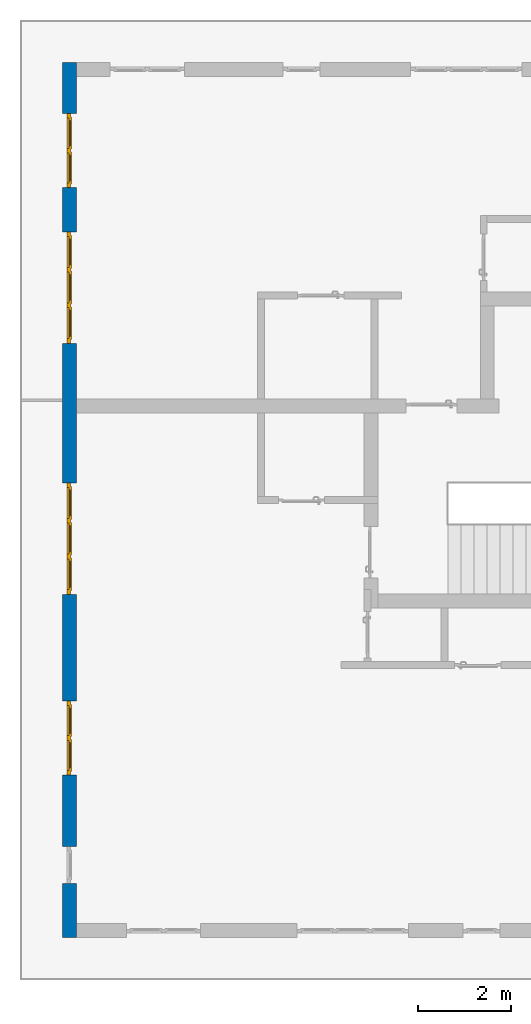
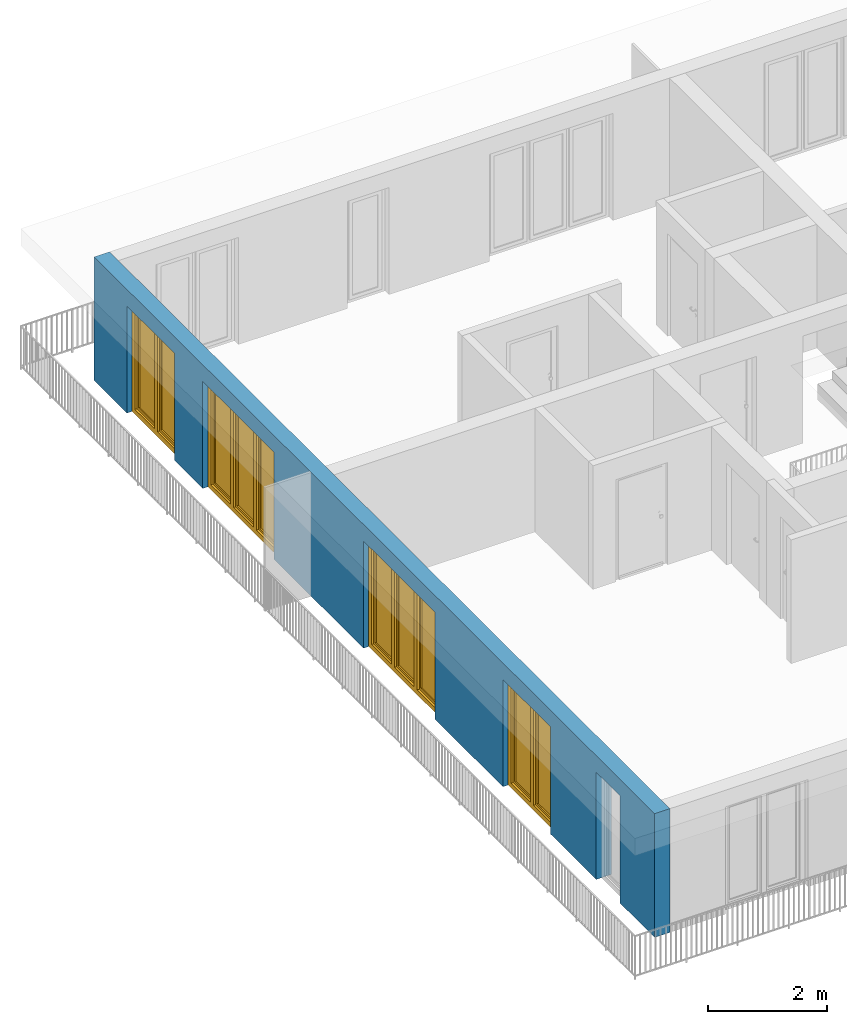
# One storey, part 7 of 48: 4 windows, 1 wall, 5 openings.
"""IFC4 building model written with IfcOpenShell, lengths in metres."""

from ifc_helpers import new_model, entity, si_unit, converted_unit, derived_unit, direction, frame, origin_with_axes, place, context, subcontext, project, spatial, polygons, source, transform, mapped, material, type_object, element, fill, save


model = new_model("IFC4")

# Units and contexts
model_context = context("Model", 3, precision=1e-05, world=origin_with_axes(), true_north=direction((0.0, 1.0)))
body_context = subcontext(model_context, "Body", "Model", "MODEL_VIEW")
ifc_project = project(units=[si_unit("LENGTHUNIT", "METRE"), si_unit("AREAUNIT", "SQUARE_METRE"), si_unit("VOLUMEUNIT", "CUBIC_METRE"), converted_unit("PLANEANGLEUNIT", "DEGREE", entity("IfcPlaneAngleMeasure", 0.0174532925199), si_unit("PLANEANGLEUNIT", "RADIAN"), dimensions=[0, 0, 0, 0, 0, 0, 0]), converted_unit("TIMEUNIT", "Year", entity("IfcTimeMeasure", 31556926.0), si_unit("TIMEUNIT", "SECOND"), dimensions=[0, 0, 1, 0, 0, 0, 0]), si_unit("MASSUNIT", "GRAM", prefix="KILO"), si_unit("THERMODYNAMICTEMPERATUREUNIT", "DEGREE_CELSIUS"), si_unit("LUMINOUSINTENSITYUNIT", "LUMEN"), si_unit("ENERGYUNIT", "JOULE", prefix="MEGA"), derived_unit("THERMALCONDUCTANCEUNIT", [(si_unit("POWERUNIT", "WATT"), 1), (si_unit("LENGTHUNIT", "METRE"), -1), (si_unit("THERMODYNAMICTEMPERATUREUNIT", "KELVIN"), -1)]), derived_unit("SPECIFICHEATCAPACITYUNIT", [(si_unit("ENERGYUNIT", "JOULE"), 1), (si_unit("MASSUNIT", "GRAM", prefix="KILO"), -1), (si_unit("THERMODYNAMICTEMPERATUREUNIT", "KELVIN"), -1)]), derived_unit("MASSDENSITYUNIT", [(si_unit("MASSUNIT", "GRAM", prefix="KILO"), 1), (si_unit("VOLUMEUNIT", "CUBIC_METRE"), -1)])], contexts=[model_context])

# Site, building, storey
site_placement = place(None, origin_with_axes())
site = spatial("IfcSite", under=ifc_project, at=site_placement, CompositionType="ELEMENT")
building_placement = place(site_placement, origin_with_axes())
building = spatial("IfcBuilding", under=site, at=building_placement, CompositionType="ELEMENT")
storey_placement = place(building_placement, frame((0.0, 0.0, 3.4), z_axis=(0.0, 0.0, 1.0), x_axis=(1.0, 0.0, 0.0)))
storey = spatial("IfcBuildingStorey", under=building, at=storey_placement, Name="1. Geschoss", CompositionType="ELEMENT", Elevation=3.4)

# Wall, openings, windows
ifc_material = material()
wall_type = type_object("IfcWallType", Name="300", PredefinedType="NOTDEFINED")
wall_placement = place(storey_placement, frame((-11.7421993804, -9.92881223104, 0.0), z_axis=(0.0, 0.0, 1.0), x_axis=(0.0, 1.0, 0.0)))
wall = element("IfcWall", 1, at=wall_placement, inside=storey, type_object=wall_type, material=ifc_material, Name="Wand-001", PredefinedType="NOTDEFINED", context=body_context, shape_type="Tessellation", body=[
    polygons([(1.16441876325, -0.3, 0.0), (1.16441876325, -0.3, 2.2), (1.96441876325, -0.3, 2.2), (1.96441876325, -0.3, 0.0), (3.5, -0.3, 0.0), (3.5, -0.3, 2.2), (5.1, -0.3, 2.2), (5.1, -0.3, 0.0), (7.3921181063, -0.3, 0.0), (7.3921181063, -0.3, 2.2), (9.7921181063, -0.3, 2.2), (9.7921181063, -0.3, 0.0), (12.8, -0.3, 0.0), (12.8, -0.3, 2.2), (15.2, -0.3, 2.2), (15.2, -0.3, 0.0), (16.15, -0.3, 0.0), (16.15, -0.3, 2.2), (17.75, -0.3, 2.2), (17.75, -0.3, 0.0), (18.85, -0.3, 0.0), (18.85, -0.3, 2.54), (0.0, -0.3, 2.54), (0.0, -0.3, 0.0), (1.16441876325, -0.1, 0.0), (1.16441876325, -0.1, 2.2), (1.96441876325, -0.1, 2.2), (1.96441876325, -0.1, 0.0), (1.96441876325, 0.0, 0.0), (3.5, 0.0, 0.0), (3.5, -0.1, 0.0), (3.5, -0.1, 2.2), (5.1, -0.1, 2.2), (5.1, -0.1, 0.0), (5.1, 0.0, 0.0), (7.3921181063, 0.0, 0.0), (7.3921181063, -0.1, 0.0), (7.3921181063, -0.1, 2.2), (9.7921181063, -0.1, 2.2), (9.7921181063, -0.1, 0.0), (9.7921181063, 0.0, 0.0), (12.8, 0.0, 0.0), (12.8, -0.1, 0.0), (12.8, -0.1, 2.2), (15.2, -0.1, 2.2), (15.2, -0.1, 0.0), (15.2, 0.0, 0.0), (16.15, 0.0, 0.0), (16.15, -0.1, 0.0), (16.15, -0.1, 2.2), (17.75, -0.1, 2.2), (17.75, -0.1, 0.0), (17.75, 0.0, 0.0), (18.85, 0.0, 0.0), (18.85, 0.0, 2.54), (0.0, 0.0, 2.54), (0.0, 0.0, 0.0), (1.16441876325, 0.0, 0.0), (1.16441876325, 0.0, 2.2), (1.96441876325, 0.0, 2.2), (17.75, 0.0, 2.2), (16.15, 0.0, 2.2), (15.2, 0.0, 2.2), (12.8, 0.0, 2.2), (9.7921181063, 0.0, 2.2), (7.3921181063, 0.0, 2.2), (5.1, 0.0, 2.2), (3.5, 0.0, 2.2)], [[[1, 2, 3, 4, 5, 6, 7, 8, 9, 10, 11, 12, 13, 14, 15, 16, 17, 18, 19, 20, 21, 22, 23, 24]], [[2, 1, 25, 26]], [[3, 2, 26, 27]], [[4, 3, 27, 28]], [[4, 28, 29, 30, 31, 5]], [[31, 32, 6, 5]], [[32, 33, 7, 6]], [[33, 34, 8, 7]], [[8, 34, 35, 36, 37, 9]], [[10, 9, 37, 38]], [[11, 10, 38, 39]], [[12, 11, 39, 40]], [[12, 40, 41, 42, 43, 13]], [[43, 44, 14, 13]], [[44, 45, 15, 14]], [[45, 46, 16, 15]], [[16, 46, 47, 48, 49, 17]], [[18, 17, 49, 50]], [[19, 18, 50, 51]], [[20, 19, 51, 52]], [[52, 53, 54, 21, 20]], [[22, 21, 54, 55]], [[22, 55, 56, 23]], [[56, 57, 24, 23]], [[25, 1, 24, 57, 58]], [[26, 25, 58, 59]], [[27, 26, 59, 60]], [[28, 27, 60, 29]], [[30, 29, 60, 59, 58, 57, 56, 55, 54, 53, 61, 62, 48, 47, 63, 64, 42, 41, 65, 66, 36, 35, 67, 68]], [[30, 68, 32, 31]], [[68, 67, 33, 32]], [[67, 35, 34, 33]], [[38, 37, 36, 66]], [[39, 38, 66, 65]], [[40, 39, 65, 41]], [[42, 64, 44, 43]], [[64, 63, 45, 44]], [[63, 47, 46, 45]], [[50, 49, 48, 62]], [[51, 50, 62, 61]], [[52, 51, 61, 53]]], closed=True),
])
opening_1_placement = place(wall_placement, frame((16.95, 0.0, 0.0), z_axis=(0.0, 0.0, 1.0), x_axis=(1.0, 0.0, 0.0)))
opening_1 = element("IfcOpeningElement", 2, at=opening_1_placement, cuts=wall, Name="Fenster-001", context=body_context, identifier="Reference", shape_type="Tessellation", body=[
    polygons([(-0.8, -0.1, 0.0), (-0.8, -0.1, 2.2), (-0.8, 0.000999999999999, 2.2), (-0.8, 0.000999999999999, 0.0), (-0.8, -0.301, 0.0), (-0.8, -0.301, 2.2), (0.8, -0.1, 2.2), (0.8, 0.000999999999999, 2.2), (0.8, -0.301, 2.2), (0.8, 0.000999999999999, 0.0), (0.8, -0.1, 0.0), (0.8, -0.301, 0.0)], [[[1, 2, 3, 4]], [[2, 1, 5, 6]], [[7, 8, 3, 2, 6, 9]], [[8, 10, 4, 3]], [[1, 4, 10, 11, 12, 5]], [[6, 5, 12, 9]], [[7, 11, 10, 8]], [[11, 7, 9, 12]]], closed=True),
])
opening_2_placement = place(wall_placement, frame((14.0, 0.0, 0.0), z_axis=(0.0, 0.0, 1.0), x_axis=(1.0, 0.0, 0.0)))
opening_2 = element("IfcOpeningElement", 3, at=opening_2_placement, cuts=wall, Name="Fenster-002", context=body_context, identifier="Reference", shape_type="Tessellation", body=[
    polygons([(-1.2, -0.1, 0.0), (-1.2, -0.1, 2.2), (-1.2, 0.000999999999999, 2.2), (-1.2, 0.000999999999999, 0.0), (-1.2, -0.301, 0.0), (-1.2, -0.301, 2.2), (1.2, -0.1, 2.2), (1.2, 0.000999999999999, 2.2), (1.2, -0.301, 2.2), (1.2, 0.000999999999999, 0.0), (1.2, -0.1, 0.0), (1.2, -0.301, 0.0)], [[[1, 2, 3, 4]], [[2, 1, 5, 6]], [[7, 8, 3, 2, 6, 9]], [[8, 10, 4, 3]], [[1, 4, 10, 11, 12, 5]], [[6, 5, 12, 9]], [[7, 11, 10, 8]], [[11, 7, 9, 12]]], closed=True),
])
opening_3_placement = place(wall_placement, frame((8.5921181063, 0.0, 0.0), z_axis=(0.0, 0.0, 1.0), x_axis=(1.0, 0.0, 0.0)))
opening_3 = element("IfcOpeningElement", 4, at=opening_3_placement, cuts=wall, Name="Fenster-002", context=body_context, identifier="Reference", shape_type="Tessellation", body=[
    polygons([(-1.2, -0.1, 0.0), (-1.2, -0.1, 2.2), (-1.2, 0.000999999999999, 2.2), (-1.2, 0.000999999999999, 0.0), (-1.2, -0.301, 0.0), (-1.2, -0.301, 2.2), (1.2, -0.1, 2.2), (1.2, 0.000999999999999, 2.2), (1.2, -0.301, 2.2), (1.2, 0.000999999999999, 0.0), (1.2, -0.1, 0.0), (1.2, -0.301, 0.0)], [[[1, 2, 3, 4]], [[2, 1, 5, 6]], [[7, 8, 3, 2, 6, 9]], [[8, 10, 4, 3]], [[1, 4, 10, 11, 12, 5]], [[6, 5, 12, 9]], [[7, 11, 10, 8]], [[11, 7, 9, 12]]], closed=True),
])
opening_4_placement = place(wall_placement, frame((4.3, 0.0, 0.0), z_axis=(0.0, 0.0, 1.0), x_axis=(1.0, 0.0, 0.0)))
opening_4 = element("IfcOpeningElement", 5, at=opening_4_placement, cuts=wall, Name="Fenster-001", context=body_context, identifier="Reference", shape_type="Tessellation", body=[
    polygons([(-0.8, -0.1, 0.0), (-0.8, -0.1, 2.2), (-0.8, 0.000999999999999, 2.2), (-0.8, 0.000999999999999, 0.0), (-0.8, -0.301, 0.0), (-0.8, -0.301, 2.2), (0.8, -0.1, 2.2), (0.8, 0.000999999999999, 2.2), (0.8, -0.301, 2.2), (0.8, 0.000999999999999, 0.0), (0.8, -0.1, 0.0), (0.8, -0.301, 0.0)], [[[1, 2, 3, 4]], [[2, 1, 5, 6]], [[7, 8, 3, 2, 6, 9]], [[8, 10, 4, 3]], [[1, 4, 10, 11, 12, 5]], [[6, 5, 12, 9]], [[7, 11, 10, 8]], [[11, 7, 9, 12]]], closed=True),
])
opening_5_placement = place(wall_placement, frame((1.56441876325, 0.0, 0.0), z_axis=(0.0, 0.0, 1.0), x_axis=(1.0, 0.0, 0.0)))
element("IfcOpeningElement", 6, at=opening_5_placement, cuts=wall, Name="Fenster-003", context=body_context, identifier="Reference", shape_type="Tessellation", body=[
    polygons([(-0.4, -0.1, 0.0), (-0.4, -0.1, 2.2), (-0.4, 0.000999999999999, 2.2), (-0.4, 0.000999999999999, 0.0), (-0.4, -0.301, 0.0), (-0.4, -0.301, 2.2), (0.4, -0.1, 2.2), (0.4, 0.000999999999999, 2.2), (0.4, -0.301, 2.2), (0.4, 0.000999999999999, 0.0), (0.4, -0.1, 0.0), (0.4, -0.301, 0.0)], [[[1, 2, 3, 4]], [[2, 1, 5, 6]], [[7, 8, 3, 2, 6, 9]], [[8, 10, 4, 3]], [[1, 4, 10, 11, 12, 5]], [[6, 5, 12, 9]], [[7, 11, 10, 8]], [[11, 7, 9, 12]]], closed=True),
])
window_type_1 = type_object("IfcWindowType", Name="2-1+1 26", PartitioningType="DOUBLE_PANEL_VERTICAL", PredefinedType="WINDOW")
shared_shape_1 = source(origin_with_axes(), body_context, "Body", "Tessellation", [
    polygons([(0.8, -0.07, 0.0), (0.7, -0.07, 0.1), (0.7, 0.0, 0.1), (0.8, 0.0, 0.0), (0.8, -0.07, 2.2), (0.7, -0.07, 2.1), (0.7, 0.0, 2.1), (0.8, 0.0, 2.2)], [[[1, 2, 3, 4]], [[1, 5, 6, 2]], [[2, 6, 7, 3]], [[4, 3, 7, 8]], [[5, 1, 4, 8]], [[6, 5, 8, 7]]], closed=True),
    polygons([(-0.8, -0.07, 0.0), (-0.8, -0.07, 2.2), (-0.8, 0.0, 2.2), (-0.8, 0.0, 0.0), (-0.7, -0.07, 0.1), (-0.7, -0.07, 2.1), (-0.7, 0.0, 2.1), (-0.7, 0.0, 0.1)], [[[1, 2, 3, 4]], [[1, 5, 6, 2]], [[2, 6, 7, 3]], [[4, 3, 7, 8]], [[5, 1, 4, 8]], [[6, 5, 8, 7]]], closed=True),
    polygons([(0.8, -0.07, 0.0), (-0.8, -0.07, 0.0), (-0.8, 0.0, 0.0), (0.8, 0.0, 0.0), (0.7, -0.07, 0.1), (0.05, -0.07, 0.1), (-0.05, -0.07, 0.1), (-0.7, -0.07, 0.1), (-0.7, 0.0, 0.1), (-0.05, 0.0, 0.1), (0.05, 0.0, 0.1), (0.7, 0.0, 0.1)], [[[1, 2, 3, 4]], [[1, 5, 6, 7, 8, 2]], [[2, 8, 9, 3]], [[4, 3, 9, 10, 11, 12]], [[5, 1, 4, 12]], [[6, 5, 12, 11]], [[7, 6, 11, 10]], [[8, 7, 10, 9]]], closed=True),
    polygons([(0.8, -0.07, 2.2), (0.7, -0.07, 2.1), (0.7, 0.0, 2.1), (0.8, 0.0, 2.2), (-0.8, -0.07, 2.2), (-0.7, -0.07, 2.1), (-0.05, -0.07, 2.1), (0.05, -0.07, 2.1), (0.05, 0.0, 2.1), (-0.05, 0.0, 2.1), (-0.7, 0.0, 2.1), (-0.8, 0.0, 2.2)], [[[1, 2, 3, 4]], [[1, 5, 6, 7, 8, 2]], [[2, 8, 9, 3]], [[4, 3, 9, 10, 11, 12]], [[5, 1, 4, 12]], [[6, 5, 12, 11]], [[7, 6, 11, 10]], [[8, 7, 10, 9]]], closed=True),
    polygons([(0.05, -0.07, 0.1), (-0.05, -0.07, 0.1), (-0.05, 0.0, 0.1), (0.05, 0.0, 0.1), (0.05, -0.07, 2.1), (-0.05, -0.07, 2.1), (-0.05, 0.0, 2.1), (0.05, 0.0, 2.1)], [[[1, 2, 3, 4]], [[1, 5, 6, 2]], [[2, 6, 7, 3]], [[4, 3, 7, 8]], [[5, 1, 4, 8]], [[6, 5, 8, 7]]], closed=True),
    polygons([(0.72, 0.0, 0.08), (0.65, 0.0, 0.15), (0.65, 0.03, 0.15), (0.72, 0.03, 0.08), (0.72, 0.0, 2.12), (0.65, 0.0, 2.05), (0.65, 0.03, 2.05), (0.72, 0.03, 2.12)], [[[1, 2, 3, 4]], [[1, 5, 6, 2]], [[2, 6, 7, 3]], [[4, 3, 7, 8]], [[5, 1, 4, 8]], [[6, 5, 8, 7]]], closed=True),
    polygons([(0.03, 0.0, 0.08), (0.03, 0.03, 0.08), (0.1, 0.03, 0.15), (0.1, 0.0, 0.15), (0.03, 0.0, 2.12), (0.03, 0.03, 2.12), (0.1, 0.03, 2.05), (0.1, 0.0, 2.05)], [[[1, 2, 3, 4]], [[5, 6, 2, 1]], [[2, 6, 7, 3]], [[4, 3, 7, 8]], [[1, 4, 8, 5]], [[8, 7, 6, 5]]], closed=True),
    polygons([(0.72, 0.0, 0.08), (0.03, 0.0, 0.08), (0.03, 0.03, 0.08), (0.72, 0.03, 0.08), (0.65, 0.0, 0.15), (0.1, 0.0, 0.15), (0.1, 0.03, 0.15), (0.65, 0.03, 0.15)], [[[1, 2, 3, 4]], [[1, 5, 6, 2]], [[2, 6, 7, 3]], [[4, 3, 7, 8]], [[5, 1, 4, 8]], [[6, 5, 8, 7]]], closed=True),
    polygons([(0.72, 0.0, 2.12), (0.72, 0.03, 2.12), (0.03, 0.03, 2.12), (0.03, 0.0, 2.12), (0.65, 0.0, 2.05), (0.65, 0.03, 2.05), (0.1, 0.03, 2.05), (0.1, 0.0, 2.05)], [[[1, 2, 3, 4]], [[5, 6, 2, 1]], [[2, 6, 7, 3]], [[4, 3, 7, 8]], [[1, 4, 8, 5]], [[8, 7, 6, 5]]], closed=True),
    polygons([(0.7, -0.03, 0.1), (0.65, -0.03, 0.15), (0.65, 0.0, 0.15), (0.7, 0.0, 0.1), (0.7, -0.03, 2.1), (0.65, -0.03, 2.05), (0.65, 0.0, 2.05), (0.7, 0.0, 2.1)], [[[1, 2, 3, 4]], [[1, 5, 6, 2]], [[2, 6, 7, 3]], [[4, 3, 7, 8]], [[5, 1, 4, 8]], [[6, 5, 8, 7]]], closed=True),
    polygons([(0.05, -0.03, 0.1), (0.05, 0.0, 0.1), (0.1, 0.0, 0.15), (0.1, -0.03, 0.15), (0.05, -0.03, 2.1), (0.05, 0.0, 2.1), (0.1, 0.0, 2.05), (0.1, -0.03, 2.05)], [[[1, 2, 3, 4]], [[5, 6, 2, 1]], [[2, 6, 7, 3]], [[4, 3, 7, 8]], [[1, 4, 8, 5]], [[8, 7, 6, 5]]], closed=True),
    polygons([(0.7, -0.03, 0.1), (0.05, -0.03, 0.1), (0.05, 0.0, 0.1), (0.7, 0.0, 0.1), (0.65, -0.03, 0.15), (0.1, -0.03, 0.15), (0.1, 0.0, 0.15), (0.65, 0.0, 0.15)], [[[1, 2, 3, 4]], [[1, 5, 6, 2]], [[2, 6, 7, 3]], [[4, 3, 7, 8]], [[5, 1, 4, 8]], [[6, 5, 8, 7]]], closed=True),
    polygons([(0.7, -0.03, 2.1), (0.7, 0.0, 2.1), (0.05, 0.0, 2.1), (0.05, -0.03, 2.1), (0.65, -0.03, 2.05), (0.65, 0.0, 2.05), (0.1, 0.0, 2.05), (0.1, -0.03, 2.05)], [[[1, 2, 3, 4]], [[5, 6, 2, 1]], [[2, 6, 7, 3]], [[4, 3, 7, 8]], [[1, 4, 8, 5]], [[8, 7, 6, 5]]], closed=True),
    polygons([(0.65, -0.005, 0.15), (0.1, -0.005, 0.15), (0.1, 0.005, 0.15), (0.65, 0.005, 0.15), (0.65, -0.005, 2.05), (0.1, -0.005, 2.05), (0.1, 0.005, 2.05), (0.65, 0.005, 2.05)], [[[1, 2, 3, 4]], [[1, 5, 6, 2]], [[2, 6, 7, 3]], [[4, 3, 7, 8]], [[5, 1, 4, 8]], [[6, 5, 8, 7]]], closed=True),
    polygons([(-0.03, 0.0, 0.08), (-0.1, 0.0, 0.15), (-0.1, 0.03, 0.15), (-0.03, 0.03, 0.08), (-0.03, 0.0, 2.12), (-0.1, 0.0, 2.05), (-0.1, 0.03, 2.05), (-0.03, 0.03, 2.12)], [[[1, 2, 3, 4]], [[1, 5, 6, 2]], [[2, 6, 7, 3]], [[4, 3, 7, 8]], [[5, 1, 4, 8]], [[6, 5, 8, 7]]], closed=True),
    polygons([(-0.72, 0.0, 0.08), (-0.72, 0.03, 0.08), (-0.65, 0.03, 0.15), (-0.65, 0.0, 0.15), (-0.72, 0.0, 2.12), (-0.72, 0.03, 2.12), (-0.65, 0.03, 2.05), (-0.65, 0.0, 2.05)], [[[1, 2, 3, 4]], [[5, 6, 2, 1]], [[2, 6, 7, 3]], [[4, 3, 7, 8]], [[1, 4, 8, 5]], [[8, 7, 6, 5]]], closed=True),
    polygons([(-0.03, 0.0, 0.08), (-0.72, 0.0, 0.08), (-0.72, 0.03, 0.08), (-0.03, 0.03, 0.08), (-0.1, 0.0, 0.15), (-0.65, 0.0, 0.15), (-0.65, 0.03, 0.15), (-0.1, 0.03, 0.15)], [[[1, 2, 3, 4]], [[1, 5, 6, 2]], [[2, 6, 7, 3]], [[4, 3, 7, 8]], [[5, 1, 4, 8]], [[6, 5, 8, 7]]], closed=True),
    polygons([(-0.03, 0.0, 2.12), (-0.03, 0.03, 2.12), (-0.72, 0.03, 2.12), (-0.72, 0.0, 2.12), (-0.1, 0.0, 2.05), (-0.1, 0.03, 2.05), (-0.65, 0.03, 2.05), (-0.65, 0.0, 2.05)], [[[1, 2, 3, 4]], [[5, 6, 2, 1]], [[2, 6, 7, 3]], [[4, 3, 7, 8]], [[1, 4, 8, 5]], [[8, 7, 6, 5]]], closed=True),
    polygons([(-0.05, -0.03, 0.1), (-0.1, -0.03, 0.15), (-0.1, 0.0, 0.15), (-0.05, 0.0, 0.1), (-0.05, -0.03, 2.1), (-0.1, -0.03, 2.05), (-0.1, 0.0, 2.05), (-0.05, 0.0, 2.1)], [[[1, 2, 3, 4]], [[1, 5, 6, 2]], [[2, 6, 7, 3]], [[4, 3, 7, 8]], [[5, 1, 4, 8]], [[6, 5, 8, 7]]], closed=True),
    polygons([(-0.7, -0.03, 0.1), (-0.7, 0.0, 0.1), (-0.65, 0.0, 0.15), (-0.65, -0.03, 0.15), (-0.7, -0.03, 2.1), (-0.7, 0.0, 2.1), (-0.65, 0.0, 2.05), (-0.65, -0.03, 2.05)], [[[1, 2, 3, 4]], [[5, 6, 2, 1]], [[2, 6, 7, 3]], [[4, 3, 7, 8]], [[1, 4, 8, 5]], [[8, 7, 6, 5]]], closed=True),
    polygons([(-0.05, -0.03, 0.1), (-0.7, -0.03, 0.1), (-0.7, 0.0, 0.1), (-0.05, 0.0, 0.1), (-0.1, -0.03, 0.15), (-0.65, -0.03, 0.15), (-0.65, 0.0, 0.15), (-0.1, 0.0, 0.15)], [[[1, 2, 3, 4]], [[1, 5, 6, 2]], [[2, 6, 7, 3]], [[4, 3, 7, 8]], [[5, 1, 4, 8]], [[6, 5, 8, 7]]], closed=True),
    polygons([(-0.05, -0.03, 2.1), (-0.05, 0.0, 2.1), (-0.7, 0.0, 2.1), (-0.7, -0.03, 2.1), (-0.1, -0.03, 2.05), (-0.1, 0.0, 2.05), (-0.65, 0.0, 2.05), (-0.65, -0.03, 2.05)], [[[1, 2, 3, 4]], [[5, 6, 2, 1]], [[2, 6, 7, 3]], [[4, 3, 7, 8]], [[1, 4, 8, 5]], [[8, 7, 6, 5]]], closed=True),
    polygons([(-0.1, -0.005, 0.15), (-0.65, -0.005, 0.15), (-0.65, 0.005, 0.15), (-0.1, 0.005, 0.15), (-0.1, -0.005, 2.05), (-0.65, -0.005, 2.05), (-0.65, 0.005, 2.05), (-0.1, 0.005, 2.05)], [[[1, 2, 3, 4]], [[1, 5, 6, 2]], [[2, 6, 7, 3]], [[4, 3, 7, 8]], [[5, 1, 4, 8]], [[6, 5, 8, 7]]], closed=True),
])
window_1_placement = place(opening_1_placement, frame((0.8, 0.0, 0.0), z_axis=(0.0, 0.0, 1.0), x_axis=(-1.0, 0.0, 0.0)))
window_1 = element("IfcWindow", 7, at=window_1_placement, inside=storey, type_object=window_type_1, Name="Fenster-001", OverallHeight=2.2, OverallWidth=1.6, PredefinedType="WINDOW", context=body_context, shape_type="MappedRepresentation", body=[
    mapped(shared_shape_1, transform((0.8, 0.17, 0.0))),
])
fill(opening_1, window_1)
window_2_placement = place(opening_4_placement, frame((0.8, 0.0, 0.0), z_axis=(0.0, 0.0, 1.0), x_axis=(-1.0, 0.0, 0.0)))
window_2 = element("IfcWindow", 8, at=window_2_placement, inside=storey, type_object=window_type_1, Name="Fenster-001", OverallHeight=2.2, OverallWidth=1.6, PredefinedType="WINDOW", context=body_context, shape_type="MappedRepresentation", body=[
    mapped(shared_shape_1, transform((0.8, 0.17, 0.0))),
])
fill(opening_4, window_2)
window_type_2 = type_object("IfcWindowType", Name="3-1+1+1 26", PartitioningType="TRIPLE_PANEL_VERTICAL", PredefinedType="WINDOW")
shared_shape_2 = source(origin_with_axes(), body_context, "Body", "Tessellation", [
    polygons([(1.2, -0.07, 0.0), (1.1, -0.07, 0.1), (1.1, 0.0, 0.1), (1.2, 0.0, 0.0), (1.2, -0.07, 2.2), (1.1, -0.07, 2.1), (1.1, 0.0, 2.1), (1.2, 0.0, 2.2)], [[[1, 2, 3, 4]], [[1, 5, 6, 2]], [[2, 6, 7, 3]], [[4, 3, 7, 8]], [[5, 1, 4, 8]], [[6, 5, 8, 7]]], closed=True),
    polygons([(-1.2, -0.07, 0.0), (-1.2, -0.07, 2.2), (-1.2, 0.0, 2.2), (-1.2, 0.0, 0.0), (-1.1, -0.07, 0.1), (-1.1, -0.07, 2.1), (-1.1, 0.0, 2.1), (-1.1, 0.0, 0.1)], [[[1, 2, 3, 4]], [[1, 5, 6, 2]], [[2, 6, 7, 3]], [[4, 3, 7, 8]], [[5, 1, 4, 8]], [[6, 5, 8, 7]]], closed=True),
    polygons([(1.2, -0.07, 0.0), (-1.2, -0.07, 0.0), (-1.2, 0.0, 0.0), (1.2, 0.0, 0.0), (1.1, -0.07, 0.1), (0.433333333333, -0.07, 0.1), (0.333333333333, -0.07, 0.1), (-0.333333333333, -0.07, 0.1), (-0.433333333333, -0.07, 0.1), (-1.1, -0.07, 0.1), (-1.1, 0.0, 0.1), (-0.433333333333, 0.0, 0.1), (-0.333333333333, 0.0, 0.1), (0.333333333333, 0.0, 0.1), (0.433333333333, 0.0, 0.1), (1.1, 0.0, 0.1)], [[[1, 2, 3, 4]], [[1, 5, 6, 7, 8, 9, 10, 2]], [[2, 10, 11, 3]], [[4, 3, 11, 12, 13, 14, 15, 16]], [[5, 1, 4, 16]], [[6, 5, 16, 15]], [[7, 6, 15, 14]], [[8, 7, 14, 13]], [[9, 8, 13, 12]], [[10, 9, 12, 11]]], closed=True),
    polygons([(1.2, -0.07, 2.2), (1.1, -0.07, 2.1), (1.1, 0.0, 2.1), (1.2, 0.0, 2.2), (-1.2, -0.07, 2.2), (-1.1, -0.07, 2.1), (-0.433333333333, -0.07, 2.1), (-0.333333333333, -0.07, 2.1), (0.333333333333, -0.07, 2.1), (0.433333333333, -0.07, 2.1), (0.433333333333, 0.0, 2.1), (0.333333333333, 0.0, 2.1), (-0.333333333333, 0.0, 2.1), (-0.433333333333, 0.0, 2.1), (-1.1, 0.0, 2.1), (-1.2, 0.0, 2.2)], [[[1, 2, 3, 4]], [[1, 5, 6, 7, 8, 9, 10, 2]], [[2, 10, 11, 3]], [[4, 3, 11, 12, 13, 14, 15, 16]], [[5, 1, 4, 16]], [[6, 5, 16, 15]], [[7, 6, 15, 14]], [[8, 7, 14, 13]], [[9, 8, 13, 12]], [[10, 9, 12, 11]]], closed=True),
    polygons([(-0.333333333333, -0.07, 0.1), (-0.433333333333, -0.07, 0.1), (-0.433333333333, 0.0, 0.1), (-0.333333333333, 0.0, 0.1), (-0.333333333333, -0.07, 2.1), (-0.433333333333, -0.07, 2.1), (-0.433333333333, 0.0, 2.1), (-0.333333333333, 0.0, 2.1)], [[[1, 2, 3, 4]], [[1, 5, 6, 2]], [[2, 6, 7, 3]], [[4, 3, 7, 8]], [[5, 1, 4, 8]], [[6, 5, 8, 7]]], closed=True),
    polygons([(0.433333333333, -0.07, 0.1), (0.333333333333, -0.07, 0.1), (0.333333333333, 0.0, 0.1), (0.433333333333, 0.0, 0.1), (0.433333333333, -0.07, 2.1), (0.333333333333, -0.07, 2.1), (0.333333333333, 0.0, 2.1), (0.433333333333, 0.0, 2.1)], [[[1, 2, 3, 4]], [[1, 5, 6, 2]], [[2, 6, 7, 3]], [[4, 3, 7, 8]], [[5, 1, 4, 8]], [[6, 5, 8, 7]]], closed=True),
    polygons([(1.12, 0.0, 0.08), (1.05, 0.0, 0.15), (1.05, 0.03, 0.15), (1.12, 0.03, 0.08), (1.12, 0.0, 2.12), (1.05, 0.0, 2.05), (1.05, 0.03, 2.05), (1.12, 0.03, 2.12)], [[[1, 2, 3, 4]], [[1, 5, 6, 2]], [[2, 6, 7, 3]], [[4, 3, 7, 8]], [[5, 1, 4, 8]], [[6, 5, 8, 7]]], closed=True),
    polygons([(0.413333333333, 0.0, 0.08), (0.413333333333, 0.03, 0.08), (0.483333333333, 0.03, 0.15), (0.483333333333, 0.0, 0.15), (0.413333333333, 0.0, 2.12), (0.413333333333, 0.03, 2.12), (0.483333333333, 0.03, 2.05), (0.483333333333, 0.0, 2.05)], [[[1, 2, 3, 4]], [[5, 6, 2, 1]], [[2, 6, 7, 3]], [[4, 3, 7, 8]], [[1, 4, 8, 5]], [[8, 7, 6, 5]]], closed=True),
    polygons([(1.12, 0.0, 0.08), (0.413333333333, 0.0, 0.08), (0.413333333333, 0.03, 0.08), (1.12, 0.03, 0.08), (1.05, 0.0, 0.15), (0.483333333333, 0.0, 0.15), (0.483333333333, 0.03, 0.15), (1.05, 0.03, 0.15)], [[[1, 2, 3, 4]], [[1, 5, 6, 2]], [[2, 6, 7, 3]], [[4, 3, 7, 8]], [[5, 1, 4, 8]], [[6, 5, 8, 7]]], closed=True),
    polygons([(1.12, 0.0, 2.12), (1.12, 0.03, 2.12), (0.413333333333, 0.03, 2.12), (0.413333333333, 0.0, 2.12), (1.05, 0.0, 2.05), (1.05, 0.03, 2.05), (0.483333333333, 0.03, 2.05), (0.483333333333, 0.0, 2.05)], [[[1, 2, 3, 4]], [[5, 6, 2, 1]], [[2, 6, 7, 3]], [[4, 3, 7, 8]], [[1, 4, 8, 5]], [[8, 7, 6, 5]]], closed=True),
    polygons([(1.1, -0.03, 0.1), (1.05, -0.03, 0.15), (1.05, 0.0, 0.15), (1.1, 0.0, 0.1), (1.1, -0.03, 2.1), (1.05, -0.03, 2.05), (1.05, 0.0, 2.05), (1.1, 0.0, 2.1)], [[[1, 2, 3, 4]], [[1, 5, 6, 2]], [[2, 6, 7, 3]], [[4, 3, 7, 8]], [[5, 1, 4, 8]], [[6, 5, 8, 7]]], closed=True),
    polygons([(0.433333333333, -0.03, 0.1), (0.433333333333, 0.0, 0.1), (0.483333333333, 0.0, 0.15), (0.483333333333, -0.03, 0.15), (0.433333333333, -0.03, 2.1), (0.433333333333, 0.0, 2.1), (0.483333333333, 0.0, 2.05), (0.483333333333, -0.03, 2.05)], [[[1, 2, 3, 4]], [[5, 6, 2, 1]], [[2, 6, 7, 3]], [[4, 3, 7, 8]], [[1, 4, 8, 5]], [[8, 7, 6, 5]]], closed=True),
    polygons([(1.1, -0.03, 0.1), (0.433333333333, -0.03, 0.1), (0.433333333333, 0.0, 0.1), (1.1, 0.0, 0.1), (1.05, -0.03, 0.15), (0.483333333333, -0.03, 0.15), (0.483333333333, 0.0, 0.15), (1.05, 0.0, 0.15)], [[[1, 2, 3, 4]], [[1, 5, 6, 2]], [[2, 6, 7, 3]], [[4, 3, 7, 8]], [[5, 1, 4, 8]], [[6, 5, 8, 7]]], closed=True),
    polygons([(1.1, -0.03, 2.1), (1.1, 0.0, 2.1), (0.433333333333, 0.0, 2.1), (0.433333333333, -0.03, 2.1), (1.05, -0.03, 2.05), (1.05, 0.0, 2.05), (0.483333333333, 0.0, 2.05), (0.483333333333, -0.03, 2.05)], [[[1, 2, 3, 4]], [[5, 6, 2, 1]], [[2, 6, 7, 3]], [[4, 3, 7, 8]], [[1, 4, 8, 5]], [[8, 7, 6, 5]]], closed=True),
    polygons([(1.05, -0.005, 0.15), (0.483333333333, -0.005, 0.15), (0.483333333333, 0.005, 0.15), (1.05, 0.005, 0.15), (1.05, -0.005, 2.05), (0.483333333333, -0.005, 2.05), (0.483333333333, 0.005, 2.05), (1.05, 0.005, 2.05)], [[[1, 2, 3, 4]], [[1, 5, 6, 2]], [[2, 6, 7, 3]], [[4, 3, 7, 8]], [[5, 1, 4, 8]], [[6, 5, 8, 7]]], closed=True),
    polygons([(0.353333333333, 0.0, 0.08), (0.283333333333, 0.0, 0.15), (0.283333333333, 0.03, 0.15), (0.353333333333, 0.03, 0.08), (0.353333333333, 0.0, 2.12), (0.283333333333, 0.0, 2.05), (0.283333333333, 0.03, 2.05), (0.353333333333, 0.03, 2.12)], [[[1, 2, 3, 4]], [[1, 5, 6, 2]], [[2, 6, 7, 3]], [[4, 3, 7, 8]], [[5, 1, 4, 8]], [[6, 5, 8, 7]]], closed=True),
    polygons([(-0.353333333333, 0.0, 0.08), (-0.353333333333, 0.03, 0.08), (-0.283333333333, 0.03, 0.15), (-0.283333333333, 0.0, 0.15), (-0.353333333333, 0.0, 2.12), (-0.353333333333, 0.03, 2.12), (-0.283333333333, 0.03, 2.05), (-0.283333333333, 0.0, 2.05)], [[[1, 2, 3, 4]], [[5, 6, 2, 1]], [[2, 6, 7, 3]], [[4, 3, 7, 8]], [[1, 4, 8, 5]], [[8, 7, 6, 5]]], closed=True),
    polygons([(0.353333333333, 0.0, 0.08), (-0.353333333333, 0.0, 0.08), (-0.353333333333, 0.03, 0.08), (0.353333333333, 0.03, 0.08), (0.283333333333, 0.0, 0.15), (-0.283333333333, 0.0, 0.15), (-0.283333333333, 0.03, 0.15), (0.283333333333, 0.03, 0.15)], [[[1, 2, 3, 4]], [[1, 5, 6, 2]], [[2, 6, 7, 3]], [[4, 3, 7, 8]], [[5, 1, 4, 8]], [[6, 5, 8, 7]]], closed=True),
    polygons([(0.353333333333, 0.0, 2.12), (0.353333333333, 0.03, 2.12), (-0.353333333333, 0.03, 2.12), (-0.353333333333, 0.0, 2.12), (0.283333333333, 0.0, 2.05), (0.283333333333, 0.03, 2.05), (-0.283333333333, 0.03, 2.05), (-0.283333333333, 0.0, 2.05)], [[[1, 2, 3, 4]], [[5, 6, 2, 1]], [[2, 6, 7, 3]], [[4, 3, 7, 8]], [[1, 4, 8, 5]], [[8, 7, 6, 5]]], closed=True),
    polygons([(0.333333333333, -0.03, 0.1), (0.283333333333, -0.03, 0.15), (0.283333333333, 0.0, 0.15), (0.333333333333, 0.0, 0.1), (0.333333333333, -0.03, 2.1), (0.283333333333, -0.03, 2.05), (0.283333333333, 0.0, 2.05), (0.333333333333, 0.0, 2.1)], [[[1, 2, 3, 4]], [[1, 5, 6, 2]], [[2, 6, 7, 3]], [[4, 3, 7, 8]], [[5, 1, 4, 8]], [[6, 5, 8, 7]]], closed=True),
    polygons([(-0.333333333333, -0.03, 0.1), (-0.333333333333, 0.0, 0.1), (-0.283333333333, 0.0, 0.15), (-0.283333333333, -0.03, 0.15), (-0.333333333333, -0.03, 2.1), (-0.333333333333, 0.0, 2.1), (-0.283333333333, 0.0, 2.05), (-0.283333333333, -0.03, 2.05)], [[[1, 2, 3, 4]], [[5, 6, 2, 1]], [[2, 6, 7, 3]], [[4, 3, 7, 8]], [[1, 4, 8, 5]], [[8, 7, 6, 5]]], closed=True),
    polygons([(0.333333333333, -0.03, 0.1), (-0.333333333333, -0.03, 0.1), (-0.333333333333, 0.0, 0.1), (0.333333333333, 0.0, 0.1), (0.283333333333, -0.03, 0.15), (-0.283333333333, -0.03, 0.15), (-0.283333333333, 0.0, 0.15), (0.283333333333, 0.0, 0.15)], [[[1, 2, 3, 4]], [[1, 5, 6, 2]], [[2, 6, 7, 3]], [[4, 3, 7, 8]], [[5, 1, 4, 8]], [[6, 5, 8, 7]]], closed=True),
    polygons([(0.333333333333, -0.03, 2.1), (0.333333333333, 0.0, 2.1), (-0.333333333333, 0.0, 2.1), (-0.333333333333, -0.03, 2.1), (0.283333333333, -0.03, 2.05), (0.283333333333, 0.0, 2.05), (-0.283333333333, 0.0, 2.05), (-0.283333333333, -0.03, 2.05)], [[[1, 2, 3, 4]], [[5, 6, 2, 1]], [[2, 6, 7, 3]], [[4, 3, 7, 8]], [[1, 4, 8, 5]], [[8, 7, 6, 5]]], closed=True),
    polygons([(0.283333333333, -0.005, 0.15), (-0.283333333333, -0.005, 0.15), (-0.283333333333, 0.005, 0.15), (0.283333333333, 0.005, 0.15), (0.283333333333, -0.005, 2.05), (-0.283333333333, -0.005, 2.05), (-0.283333333333, 0.005, 2.05), (0.283333333333, 0.005, 2.05)], [[[1, 2, 3, 4]], [[1, 5, 6, 2]], [[2, 6, 7, 3]], [[4, 3, 7, 8]], [[5, 1, 4, 8]], [[6, 5, 8, 7]]], closed=True),
    polygons([(-0.413333333333, 0.0, 0.08), (-0.483333333333, 0.0, 0.15), (-0.483333333333, 0.03, 0.15), (-0.413333333333, 0.03, 0.08), (-0.413333333333, 0.0, 2.12), (-0.483333333333, 0.0, 2.05), (-0.483333333333, 0.03, 2.05), (-0.413333333333, 0.03, 2.12)], [[[1, 2, 3, 4]], [[1, 5, 6, 2]], [[2, 6, 7, 3]], [[4, 3, 7, 8]], [[5, 1, 4, 8]], [[6, 5, 8, 7]]], closed=True),
    polygons([(-1.12, 0.0, 0.08), (-1.12, 0.03, 0.08), (-1.05, 0.03, 0.15), (-1.05, 0.0, 0.15), (-1.12, 0.0, 2.12), (-1.12, 0.03, 2.12), (-1.05, 0.03, 2.05), (-1.05, 0.0, 2.05)], [[[1, 2, 3, 4]], [[5, 6, 2, 1]], [[2, 6, 7, 3]], [[4, 3, 7, 8]], [[1, 4, 8, 5]], [[8, 7, 6, 5]]], closed=True),
    polygons([(-0.413333333333, 0.0, 0.08), (-1.12, 0.0, 0.08), (-1.12, 0.03, 0.08), (-0.413333333333, 0.03, 0.08), (-0.483333333333, 0.0, 0.15), (-1.05, 0.0, 0.15), (-1.05, 0.03, 0.15), (-0.483333333333, 0.03, 0.15)], [[[1, 2, 3, 4]], [[1, 5, 6, 2]], [[2, 6, 7, 3]], [[4, 3, 7, 8]], [[5, 1, 4, 8]], [[6, 5, 8, 7]]], closed=True),
    polygons([(-0.413333333333, 0.0, 2.12), (-0.413333333333, 0.03, 2.12), (-1.12, 0.03, 2.12), (-1.12, 0.0, 2.12), (-0.483333333333, 0.0, 2.05), (-0.483333333333, 0.03, 2.05), (-1.05, 0.03, 2.05), (-1.05, 0.0, 2.05)], [[[1, 2, 3, 4]], [[5, 6, 2, 1]], [[2, 6, 7, 3]], [[4, 3, 7, 8]], [[1, 4, 8, 5]], [[8, 7, 6, 5]]], closed=True),
    polygons([(-0.433333333333, -0.03, 0.1), (-0.483333333333, -0.03, 0.15), (-0.483333333333, 0.0, 0.15), (-0.433333333333, 0.0, 0.1), (-0.433333333333, -0.03, 2.1), (-0.483333333333, -0.03, 2.05), (-0.483333333333, 0.0, 2.05), (-0.433333333333, 0.0, 2.1)], [[[1, 2, 3, 4]], [[1, 5, 6, 2]], [[2, 6, 7, 3]], [[4, 3, 7, 8]], [[5, 1, 4, 8]], [[6, 5, 8, 7]]], closed=True),
    polygons([(-1.1, -0.03, 0.1), (-1.1, 0.0, 0.1), (-1.05, 0.0, 0.15), (-1.05, -0.03, 0.15), (-1.1, -0.03, 2.1), (-1.1, 0.0, 2.1), (-1.05, 0.0, 2.05), (-1.05, -0.03, 2.05)], [[[1, 2, 3, 4]], [[5, 6, 2, 1]], [[2, 6, 7, 3]], [[4, 3, 7, 8]], [[1, 4, 8, 5]], [[8, 7, 6, 5]]], closed=True),
    polygons([(-0.433333333333, -0.03, 0.1), (-1.1, -0.03, 0.1), (-1.1, 0.0, 0.1), (-0.433333333333, 0.0, 0.1), (-0.483333333333, -0.03, 0.15), (-1.05, -0.03, 0.15), (-1.05, 0.0, 0.15), (-0.483333333333, 0.0, 0.15)], [[[1, 2, 3, 4]], [[1, 5, 6, 2]], [[2, 6, 7, 3]], [[4, 3, 7, 8]], [[5, 1, 4, 8]], [[6, 5, 8, 7]]], closed=True),
    polygons([(-0.433333333333, -0.03, 2.1), (-0.433333333333, 0.0, 2.1), (-1.1, 0.0, 2.1), (-1.1, -0.03, 2.1), (-0.483333333333, -0.03, 2.05), (-0.483333333333, 0.0, 2.05), (-1.05, 0.0, 2.05), (-1.05, -0.03, 2.05)], [[[1, 2, 3, 4]], [[5, 6, 2, 1]], [[2, 6, 7, 3]], [[4, 3, 7, 8]], [[1, 4, 8, 5]], [[8, 7, 6, 5]]], closed=True),
    polygons([(-0.483333333333, -0.005, 0.15), (-1.05, -0.005, 0.15), (-1.05, 0.005, 0.15), (-0.483333333333, 0.005, 0.15), (-0.483333333333, -0.005, 2.05), (-1.05, -0.005, 2.05), (-1.05, 0.005, 2.05), (-0.483333333333, 0.005, 2.05)], [[[1, 2, 3, 4]], [[1, 5, 6, 2]], [[2, 6, 7, 3]], [[4, 3, 7, 8]], [[5, 1, 4, 8]], [[6, 5, 8, 7]]], closed=True),
])
window_3_placement = place(opening_2_placement, frame((1.2, 0.0, 0.0), z_axis=(0.0, 0.0, 1.0), x_axis=(-1.0, 0.0, 0.0)))
window_3 = element("IfcWindow", 9, at=window_3_placement, inside=storey, type_object=window_type_2, Name="Fenster-002", OverallHeight=2.2, OverallWidth=2.4, PredefinedType="WINDOW", context=body_context, shape_type="MappedRepresentation", body=[
    mapped(shared_shape_2, transform((1.2, 0.17, 0.0))),
])
fill(opening_2, window_3)
window_4_placement = place(opening_3_placement, frame((1.2, 0.0, 0.0), z_axis=(0.0, 0.0, 1.0), x_axis=(-1.0, 0.0, 0.0)))
window_4 = element("IfcWindow", 10, at=window_4_placement, inside=storey, type_object=window_type_2, Name="Fenster-002", OverallHeight=2.2, OverallWidth=2.4, PredefinedType="WINDOW", context=body_context, shape_type="MappedRepresentation", body=[
    mapped(shared_shape_2, transform((1.2, 0.17, 0.0))),
])
fill(opening_3, window_4)

save(model, "model.ifc")
